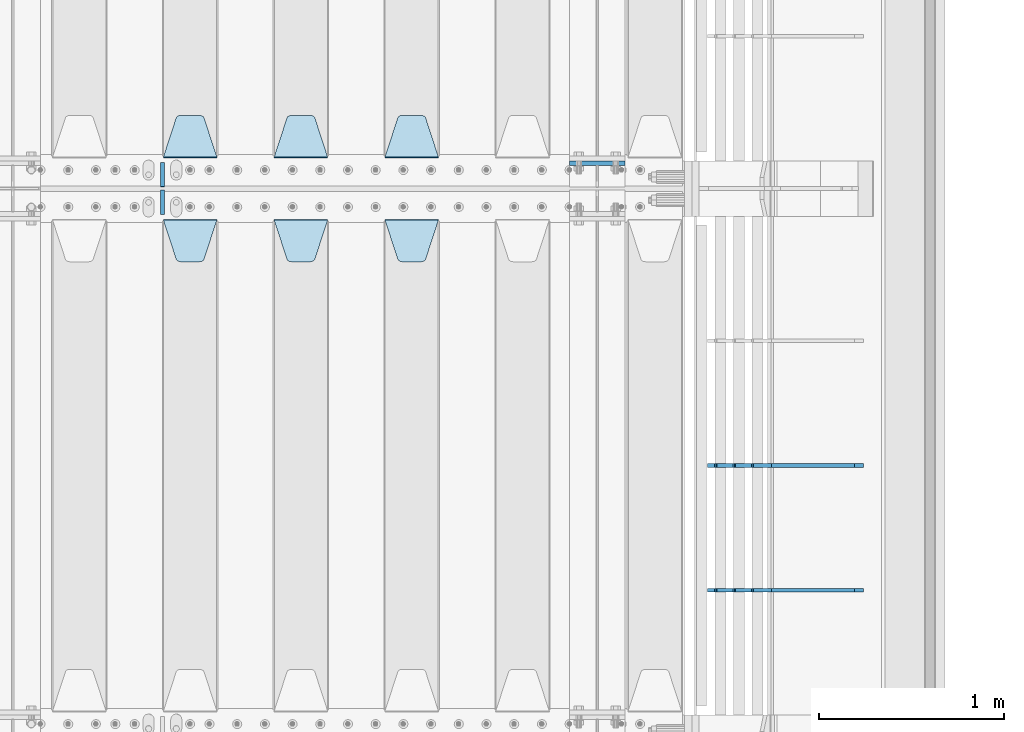
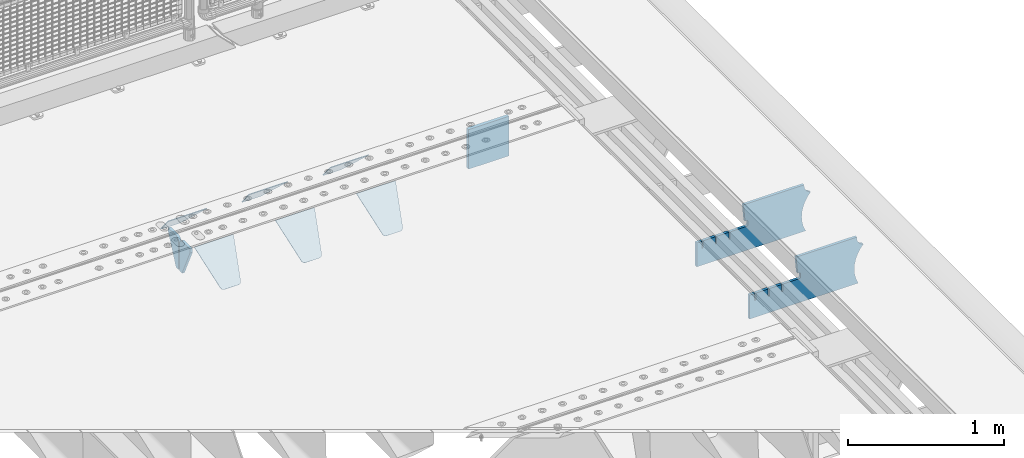
# One storey, part 190 of 219: 11 plates.
"""IFC2X3 building model written with IfcOpenShell, lengths in millimetres."""

from ifc_helpers import new_model, si_unit, frame, origin_with_axes, place, context, subcontext, project, spatial, faceted_brep, material, type_object, element, save


model = new_model("IFC2X3")

# Units and contexts
model_context = context("Model", 3, precision=1e-05, world=origin_with_axes())
body_context = subcontext(model_context, "Body", "Model", "MODEL_VIEW")
ifc_project = project(units=[si_unit("LENGTHUNIT", "METRE", prefix="MILLI"), si_unit("AREAUNIT", "SQUARE_METRE"), si_unit("VOLUMEUNIT", "CUBIC_METRE"), si_unit("MASSUNIT", "GRAM", prefix="KILO"), si_unit("TIMEUNIT", "SECOND"), si_unit("PLANEANGLEUNIT", "RADIAN"), si_unit("SOLIDANGLEUNIT", "STERADIAN"), si_unit("THERMODYNAMICTEMPERATUREUNIT", "DEGREE_CELSIUS"), si_unit("LUMINOUSINTENSITYUNIT", "LUMEN")], contexts=[model_context])

# Site, building, storey
site_placement = place(None, origin_with_axes())
site = spatial("IfcSite", under=ifc_project, at=site_placement, CompositionType="ELEMENT")
building_placement = place(site_placement, origin_with_axes())
building = spatial("IfcBuilding", under=site, at=building_placement, Name="Standard", CompositionType="ELEMENT")
storey_placement = place(building_placement, origin_with_axes())
storey = spatial("IfcBuildingStorey", under=building, at=storey_placement, Name="Undefined", CompositionType="ELEMENT", Elevation=0.0)

# Plates
ifc_material = material(Name="STEEL/S355N")
plate_type_1 = type_object("IfcPlateType", PredefinedType="NOTDEFINED")
plate_1_placement = place(storey_placement, frame((13405.0, 30137.5, -339.999999999995), z_axis=(0.0, 0.0, 1.0), x_axis=(1.0, 0.0, 0.0)))
element("IfcPlate", 1, at=plate_1_placement, inside=storey, type_object=plate_type_1, material=ifc_material, context=body_context, shape_type="Brep", body=[
    faceted_brep([(0.0, -12.5, 0.0), (0.0, -12.5, 310.0), (0.0, 12.5, 310.0), (0.0, 12.5, 0.0), (300.0, -12.5, 310.0), (300.0, 12.5, 310.0), (300.0, -12.5, 0.0), (300.0, 12.5, 0.0)], [[[0, 1, 2, 3]], [[1, 4, 5, 2]], [[4, 6, 7, 5]], [[6, 0, 3, 7]], [[5, 7, 3, 2]], [[6, 4, 1, 0]]]),
])
plate_type_2 = type_object("IfcPlateType", PredefinedType="NOTDEFINED")
plate_2_placement = place(storey_placement, frame((12405.0, 29831.767766956, -1.76776695296758), z_axis=(0.0, -0.707106781186547, -0.707106781186548), x_axis=(1.0, 0.0, 0.0)))
element("IfcPlate", 2, at=plate_2_placement, inside=storey, type_object=plate_type_2, material=ifc_material, context=body_context, shape_type="Brep", body=[
    faceted_brep([(0.0, -2.5, 0.0), (69.345504679477, -2.5, 300.171731424834), (69.345504679477, 2.49999999999636, 300.171731424831), (0.0, 2.5, 0.0), (70.9274061199576, -2.50000000000364, 304.8974424154), (70.9274061199576, 2.49999999999636, 304.8974424154), (73.3818627772307, -2.50000000000364, 309.234538108532), (73.3818627772307, 2.49999999999636, 309.234538108532), (76.6187032999569, -2.50000000000364, 313.023683126106), (76.6187032999569, 2.49999999999636, 313.023683126106), (80.5190132704993, -2.50000000000364, 316.125672595372), (80.5190132704993, 2.49999999999636, 316.125672595372), (84.9395038596831, -2.50000000000364, 318.426546230476), (84.9395038596831, 2.5, 318.426546230479), (89.7177759439237, -2.50000000000364, 319.841774983277), (89.7177759439237, 2.5, 319.841774983281), (94.6782862926502, -2.50000000000364, 320.319366455078), (94.6782862926502, 2.49999999999636, 320.319366455078), (195.32171370735, -2.50000000000364, 320.319366455078), (195.32171370735, 2.49999999999636, 320.319366455078), (200.282224056076, -2.50000000000364, 319.841774983277), (200.282224056076, 2.5, 319.841774983281), (205.060496140317, -2.50000000000364, 318.426546230476), (205.060496140317, 2.49999999999636, 318.426546230476), (209.480986729501, -2.50000000000364, 316.125672595372), (209.480986729501, 2.49999999999636, 316.125672595372), (213.381296700043, -2.50000000000364, 313.023683126106), (213.381296700043, 2.49999999999272, 313.023683126106), (216.618137222769, -2.50000000000364, 309.234538108529), (216.618137222769, 2.49999999999636, 309.234538108525), (219.072593880042, -2.50000000000364, 304.8974424154), (219.072593880042, 2.49999999999636, 304.8974424154), (220.654495320523, -2.5, 300.171731424834), (220.654495320523, 2.49999999999636, 300.171731424831), (290.0, -2.50000000000364, 3.63797880709171e-12), (290.0, 2.49999999999636, 0.0)], [[[0, 1, 2, 3]], [[1, 4, 5, 2]], [[4, 6, 7, 5]], [[6, 8, 9, 7]], [[8, 10, 11, 9]], [[10, 12, 13, 11]], [[12, 14, 15, 13]], [[14, 16, 17, 15]], [[16, 18, 19, 17]], [[18, 20, 21, 19]], [[20, 22, 23, 21]], [[22, 24, 25, 23]], [[24, 26, 27, 25]], [[26, 28, 29, 27]], [[28, 30, 31, 29]], [[30, 32, 33, 31]], [[32, 34, 35, 33]], [[34, 0, 3, 35]], [[5, 7, 9, 11, 13, 15, 17, 19, 21, 23, 25, 27, 29, 31, 33, 35, 3, 2]], [[34, 32, 30, 28, 26, 24, 22, 20, 18, 16, 14, 12, 10, 8, 6, 4, 1, 0]]]),
])
plate_3_placement = place(storey_placement, frame((11805.0, 29831.767766956, -1.76776695296758), z_axis=(0.0, -0.707106781186547, -0.707106781186548), x_axis=(1.0, 0.0, 0.0)))
element("IfcPlate", 3, at=plate_3_placement, inside=storey, type_object=plate_type_2, material=ifc_material, context=body_context, shape_type="Brep", body=[
    faceted_brep([(0.0, -2.5, 0.0), (69.345504679477, -2.5, 300.171731424834), (69.345504679477, 2.49999999999636, 300.171731424831), (0.0, 2.5, 0.0), (70.9274061199576, -2.50000000000364, 304.8974424154), (70.9274061199576, 2.49999999999636, 304.8974424154), (73.3818627772307, -2.50000000000364, 309.234538108532), (73.3818627772307, 2.49999999999636, 309.234538108532), (76.6187032999569, -2.50000000000364, 313.023683126106), (76.6187032999569, 2.49999999999636, 313.023683126106), (80.5190132704993, -2.50000000000364, 316.125672595372), (80.5190132704993, 2.49999999999636, 316.125672595372), (84.9395038596831, -2.50000000000364, 318.426546230476), (84.9395038596831, 2.5, 318.426546230479), (89.7177759439237, -2.50000000000364, 319.841774983277), (89.7177759439237, 2.5, 319.841774983281), (94.6782862926502, -2.50000000000364, 320.319366455078), (94.6782862926502, 2.49999999999636, 320.319366455078), (195.32171370735, -2.50000000000364, 320.319366455078), (195.32171370735, 2.49999999999636, 320.319366455078), (200.282224056076, -2.50000000000364, 319.841774983277), (200.282224056076, 2.5, 319.841774983281), (205.060496140317, -2.50000000000364, 318.426546230476), (205.060496140317, 2.49999999999636, 318.426546230476), (209.480986729501, -2.50000000000364, 316.125672595372), (209.480986729501, 2.49999999999636, 316.125672595372), (213.381296700043, -2.50000000000364, 313.023683126106), (213.381296700043, 2.49999999999272, 313.023683126106), (216.618137222769, -2.50000000000364, 309.234538108529), (216.618137222769, 2.49999999999636, 309.234538108525), (219.072593880042, -2.50000000000364, 304.8974424154), (219.072593880042, 2.49999999999636, 304.8974424154), (220.654495320523, -2.5, 300.171731424834), (220.654495320523, 2.49999999999636, 300.171731424831), (290.0, -2.50000000000364, 3.63797880709171e-12), (290.0, 2.49999999999636, 0.0)], [[[0, 1, 2, 3]], [[1, 4, 5, 2]], [[4, 6, 7, 5]], [[6, 8, 9, 7]], [[8, 10, 11, 9]], [[10, 12, 13, 11]], [[12, 14, 15, 13]], [[14, 16, 17, 15]], [[16, 18, 19, 17]], [[18, 20, 21, 19]], [[20, 22, 23, 21]], [[22, 24, 25, 23]], [[24, 26, 27, 25]], [[26, 28, 29, 27]], [[28, 30, 31, 29]], [[30, 32, 33, 31]], [[32, 34, 35, 33]], [[34, 0, 3, 35]], [[5, 7, 9, 11, 13, 15, 17, 19, 21, 23, 25, 27, 29, 31, 33, 35, 3, 2]], [[34, 32, 30, 28, 26, 24, 22, 20, 18, 16, 14, 12, 10, 8, 6, 4, 1, 0]]]),
])
plate_4_placement = place(storey_placement, frame((11205.0, 29831.767766956, -1.76776695296758), z_axis=(0.0, -0.707106781186547, -0.707106781186548), x_axis=(1.0, 0.0, 0.0)))
element("IfcPlate", 4, at=plate_4_placement, inside=storey, type_object=plate_type_2, material=ifc_material, context=body_context, shape_type="Brep", body=[
    faceted_brep([(0.0, -2.5, 0.0), (69.345504679477, -2.5, 300.171731424834), (69.345504679477, 2.49999999999636, 300.171731424831), (0.0, 2.5, 0.0), (70.9274061199576, -2.50000000000364, 304.8974424154), (70.9274061199576, 2.49999999999636, 304.8974424154), (73.3818627772307, -2.50000000000364, 309.234538108532), (73.3818627772307, 2.49999999999636, 309.234538108532), (76.6187032999569, -2.50000000000364, 313.023683126106), (76.6187032999569, 2.49999999999636, 313.023683126106), (80.5190132704993, -2.50000000000364, 316.125672595372), (80.5190132704993, 2.49999999999636, 316.125672595372), (84.9395038596831, -2.50000000000364, 318.426546230476), (84.9395038596831, 2.5, 318.426546230479), (89.7177759439237, -2.50000000000364, 319.841774983277), (89.7177759439237, 2.5, 319.841774983281), (94.6782862926502, -2.50000000000364, 320.319366455078), (94.6782862926502, 2.49999999999636, 320.319366455078), (195.32171370735, -2.50000000000364, 320.319366455078), (195.32171370735, 2.49999999999636, 320.319366455078), (200.282224056076, -2.50000000000364, 319.841774983277), (200.282224056076, 2.5, 319.841774983281), (205.060496140317, -2.50000000000364, 318.426546230476), (205.060496140317, 2.49999999999636, 318.426546230476), (209.480986729501, -2.50000000000364, 316.125672595372), (209.480986729501, 2.49999999999636, 316.125672595372), (213.381296700043, -2.50000000000364, 313.023683126106), (213.381296700043, 2.49999999999272, 313.023683126106), (216.618137222769, -2.50000000000364, 309.234538108529), (216.618137222769, 2.49999999999636, 309.234538108525), (219.072593880042, -2.50000000000364, 304.8974424154), (219.072593880042, 2.49999999999636, 304.8974424154), (220.654495320523, -2.5, 300.171731424834), (220.654495320523, 2.49999999999636, 300.171731424831), (290.0, -2.50000000000364, 3.63797880709171e-12), (290.0, 2.49999999999636, 0.0)], [[[0, 1, 2, 3]], [[1, 4, 5, 2]], [[4, 6, 7, 5]], [[6, 8, 9, 7]], [[8, 10, 11, 9]], [[10, 12, 13, 11]], [[12, 14, 15, 13]], [[14, 16, 17, 15]], [[16, 18, 19, 17]], [[18, 20, 21, 19]], [[20, 22, 23, 21]], [[22, 24, 25, 23]], [[24, 26, 27, 25]], [[26, 28, 29, 27]], [[28, 30, 31, 29]], [[30, 32, 33, 31]], [[32, 34, 35, 33]], [[34, 0, 3, 35]], [[5, 7, 9, 11, 13, 15, 17, 19, 21, 23, 25, 27, 29, 31, 33, 35, 3, 2]], [[34, 32, 30, 28, 26, 24, 22, 20, 18, 16, 14, 12, 10, 8, 6, 4, 1, 0]]]),
])
plate_5_placement = place(storey_placement, frame((12695.0, 30168.232233047, -1.76776695296758), z_axis=(0.0, 0.707106781186547, -0.707106781186548), x_axis=(-1.0, 0.0, 0.0)))
element("IfcPlate", 5, at=plate_5_placement, inside=storey, type_object=plate_type_2, material=ifc_material, context=body_context, shape_type="Brep", body=[
    faceted_brep([(0.0, -2.5, 0.0), (69.345504679477, -2.5, 300.171731424834), (69.345504679477, 2.49999999999636, 300.171731424831), (0.0, 2.5, 0.0), (70.9274061199576, -2.50000000000364, 304.8974424154), (70.9274061199576, 2.49999999999636, 304.8974424154), (73.3818627772307, -2.50000000000364, 309.234538108532), (73.3818627772307, 2.49999999999636, 309.234538108532), (76.6187032999569, -2.50000000000364, 313.023683126106), (76.6187032999569, 2.49999999999636, 313.023683126106), (80.5190132704993, -2.50000000000364, 316.125672595372), (80.5190132704993, 2.49999999999636, 316.125672595372), (84.9395038596831, -2.50000000000364, 318.426546230476), (84.9395038596831, 2.5, 318.426546230479), (89.7177759439237, -2.50000000000364, 319.841774983277), (89.7177759439237, 2.5, 319.841774983281), (94.6782862926502, -2.50000000000364, 320.319366455078), (94.6782862926502, 2.49999999999636, 320.319366455078), (195.32171370735, -2.50000000000364, 320.319366455078), (195.32171370735, 2.49999999999636, 320.319366455078), (200.282224056076, -2.50000000000364, 319.841774983277), (200.282224056076, 2.5, 319.841774983281), (205.060496140317, -2.50000000000364, 318.426546230476), (205.060496140317, 2.49999999999636, 318.426546230476), (209.480986729501, -2.50000000000364, 316.125672595372), (209.480986729501, 2.49999999999636, 316.125672595372), (213.381296700043, -2.50000000000364, 313.023683126106), (213.381296700043, 2.49999999999272, 313.023683126106), (216.618137222769, -2.50000000000364, 309.234538108529), (216.618137222769, 2.49999999999636, 309.234538108525), (219.072593880042, -2.50000000000364, 304.8974424154), (219.072593880042, 2.49999999999636, 304.8974424154), (220.654495320523, -2.5, 300.171731424834), (220.654495320523, 2.49999999999636, 300.171731424831), (290.0, -2.50000000000364, 3.63797880709171e-12), (290.0, 2.49999999999636, 0.0)], [[[0, 1, 2, 3]], [[1, 4, 5, 2]], [[4, 6, 7, 5]], [[6, 8, 9, 7]], [[8, 10, 11, 9]], [[10, 12, 13, 11]], [[12, 14, 15, 13]], [[14, 16, 17, 15]], [[16, 18, 19, 17]], [[18, 20, 21, 19]], [[20, 22, 23, 21]], [[22, 24, 25, 23]], [[24, 26, 27, 25]], [[26, 28, 29, 27]], [[28, 30, 31, 29]], [[30, 32, 33, 31]], [[32, 34, 35, 33]], [[34, 0, 3, 35]], [[5, 7, 9, 11, 13, 15, 17, 19, 21, 23, 25, 27, 29, 31, 33, 35, 3, 2]], [[34, 32, 30, 28, 26, 24, 22, 20, 18, 16, 14, 12, 10, 8, 6, 4, 1, 0]]]),
])
plate_6_placement = place(storey_placement, frame((12095.0, 30168.232233047, -1.76776695296758), z_axis=(0.0, 0.707106781186547, -0.707106781186548), x_axis=(-1.0, 0.0, 0.0)))
element("IfcPlate", 6, at=plate_6_placement, inside=storey, type_object=plate_type_2, material=ifc_material, context=body_context, shape_type="Brep", body=[
    faceted_brep([(0.0, -2.5, 0.0), (69.345504679477, -2.5, 300.171731424834), (69.345504679477, 2.49999999999636, 300.171731424831), (0.0, 2.5, 0.0), (70.9274061199576, -2.50000000000364, 304.8974424154), (70.9274061199576, 2.49999999999636, 304.8974424154), (73.3818627772307, -2.50000000000364, 309.234538108532), (73.3818627772307, 2.49999999999636, 309.234538108532), (76.6187032999569, -2.50000000000364, 313.023683126106), (76.6187032999569, 2.49999999999636, 313.023683126106), (80.5190132704993, -2.50000000000364, 316.125672595372), (80.5190132704993, 2.49999999999636, 316.125672595372), (84.9395038596831, -2.50000000000364, 318.426546230476), (84.9395038596831, 2.5, 318.426546230479), (89.7177759439237, -2.50000000000364, 319.841774983277), (89.7177759439237, 2.5, 319.841774983281), (94.6782862926502, -2.50000000000364, 320.319366455078), (94.6782862926502, 2.49999999999636, 320.319366455078), (195.32171370735, -2.50000000000364, 320.319366455078), (195.32171370735, 2.49999999999636, 320.319366455078), (200.282224056076, -2.50000000000364, 319.841774983277), (200.282224056076, 2.5, 319.841774983281), (205.060496140317, -2.50000000000364, 318.426546230476), (205.060496140317, 2.49999999999636, 318.426546230476), (209.480986729501, -2.50000000000364, 316.125672595372), (209.480986729501, 2.49999999999636, 316.125672595372), (213.381296700043, -2.50000000000364, 313.023683126106), (213.381296700043, 2.49999999999272, 313.023683126106), (216.618137222769, -2.50000000000364, 309.234538108529), (216.618137222769, 2.49999999999636, 309.234538108525), (219.072593880042, -2.50000000000364, 304.8974424154), (219.072593880042, 2.49999999999636, 304.8974424154), (220.654495320523, -2.5, 300.171731424834), (220.654495320523, 2.49999999999636, 300.171731424831), (290.0, -2.50000000000364, 3.63797880709171e-12), (290.0, 2.49999999999636, 0.0)], [[[0, 1, 2, 3]], [[1, 4, 5, 2]], [[4, 6, 7, 5]], [[6, 8, 9, 7]], [[8, 10, 11, 9]], [[10, 12, 13, 11]], [[12, 14, 15, 13]], [[14, 16, 17, 15]], [[16, 18, 19, 17]], [[18, 20, 21, 19]], [[20, 22, 23, 21]], [[22, 24, 25, 23]], [[24, 26, 27, 25]], [[26, 28, 29, 27]], [[28, 30, 31, 29]], [[30, 32, 33, 31]], [[32, 34, 35, 33]], [[34, 0, 3, 35]], [[5, 7, 9, 11, 13, 15, 17, 19, 21, 23, 25, 27, 29, 31, 33, 35, 3, 2]], [[34, 32, 30, 28, 26, 24, 22, 20, 18, 16, 14, 12, 10, 8, 6, 4, 1, 0]]]),
])
plate_7_placement = place(storey_placement, frame((11495.0, 30168.232233047, -1.76776695296758), z_axis=(0.0, 0.707106781186547, -0.707106781186548), x_axis=(-1.0, 0.0, 0.0)))
element("IfcPlate", 7, at=plate_7_placement, inside=storey, type_object=plate_type_2, material=ifc_material, context=body_context, shape_type="Brep", body=[
    faceted_brep([(0.0, -2.5, 0.0), (69.345504679477, -2.5, 300.171731424834), (69.345504679477, 2.49999999999636, 300.171731424831), (0.0, 2.5, 0.0), (70.9274061199576, -2.50000000000364, 304.8974424154), (70.9274061199576, 2.49999999999636, 304.8974424154), (73.3818627772307, -2.50000000000364, 309.234538108532), (73.3818627772307, 2.49999999999636, 309.234538108532), (76.6187032999569, -2.50000000000364, 313.023683126106), (76.6187032999569, 2.49999999999636, 313.023683126106), (80.5190132704993, -2.50000000000364, 316.125672595372), (80.5190132704993, 2.49999999999636, 316.125672595372), (84.9395038596831, -2.50000000000364, 318.426546230476), (84.9395038596831, 2.5, 318.426546230479), (89.7177759439237, -2.50000000000364, 319.841774983277), (89.7177759439237, 2.5, 319.841774983281), (94.6782862926502, -2.50000000000364, 320.319366455078), (94.6782862926502, 2.49999999999636, 320.319366455078), (195.32171370735, -2.50000000000364, 320.319366455078), (195.32171370735, 2.49999999999636, 320.319366455078), (200.282224056076, -2.50000000000364, 319.841774983277), (200.282224056076, 2.5, 319.841774983281), (205.060496140317, -2.50000000000364, 318.426546230476), (205.060496140317, 2.49999999999636, 318.426546230476), (209.480986729501, -2.50000000000364, 316.125672595372), (209.480986729501, 2.49999999999636, 316.125672595372), (213.381296700043, -2.50000000000364, 313.023683126106), (213.381296700043, 2.49999999999272, 313.023683126106), (216.618137222769, -2.50000000000364, 309.234538108529), (216.618137222769, 2.49999999999636, 309.234538108525), (219.072593880042, -2.50000000000364, 304.8974424154), (219.072593880042, 2.49999999999636, 304.8974424154), (220.654495320523, -2.5, 300.171731424834), (220.654495320523, 2.49999999999636, 300.171731424831), (290.0, -2.50000000000364, 3.63797880709171e-12), (290.0, 2.49999999999636, 0.0)], [[[0, 1, 2, 3]], [[1, 4, 5, 2]], [[4, 6, 7, 5]], [[6, 8, 9, 7]], [[8, 10, 11, 9]], [[10, 12, 13, 11]], [[12, 14, 15, 13]], [[14, 16, 17, 15]], [[16, 18, 19, 17]], [[18, 20, 21, 19]], [[20, 22, 23, 21]], [[22, 24, 25, 23]], [[24, 26, 27, 25]], [[26, 28, 29, 27]], [[28, 30, 31, 29]], [[30, 32, 33, 31]], [[32, 34, 35, 33]], [[34, 0, 3, 35]], [[5, 7, 9, 11, 13, 15, 17, 19, 21, 23, 25, 27, 29, 31, 33, 35, 3, 2]], [[34, 32, 30, 28, 26, 24, 22, 20, 18, 16, 14, 12, 10, 8, 6, 4, 1, 0]]]),
])
plate_type_3 = type_object("IfcPlateType", PredefinedType="NOTDEFINED")
for number, where, z_axis, x_axis in (
    (8, (11200.0, 30140.0, -30.0), (0.0, 0.0, -1.0), (0.0, -1.0, 0.0)),
    (9, (11200.0, 29860.0, -30.0), (0.0, 0.0, -1.0), (0.0, 1.0, 0.0)),
):
    element("IfcPlate", number, at=place(storey_placement, frame(where, z_axis=z_axis, x_axis=x_axis)), inside=storey, type_object=plate_type_3, material=ifc_material, context=body_context, shape_type="Brep", body=[
        faceted_brep([(0.0, -10.0, 0.0), (0.0, -10.0, 30.0), (0.0, 10.0, 30.0), (0.0, 10.0, 0.0), (102.0, -10.0, 250.0), (102.0, 10.0, 250.0), (132.0, -10.0, 250.0), (132.0, 10.0, 250.0), (132.0, -10.0, 30.0), (132.0, 10.0, 30.0), (131.544232590368, -10.0, 24.790554669992), (131.544232590368, 10.0, 24.790554669992), (130.190778623579, -10.0, 19.7393957002299), (130.190778623579, 10.0, 19.7393957002299), (127.980762113533, -10.0, 15.0), (127.980762113533, 10.0, 15.0), (124.98133329357, -10.0, 10.7163717094038), (124.98133329357, 10.0, 10.7163717094038), (121.283628290596, -10.0, 7.01866670643062), (121.283628290596, 10.0, 7.01866670643062), (117.0, -10.0, 4.01923788646684), (117.0, 10.0, 4.01923788646684), (112.260604299769, -10.0, 1.80922137642278), (112.260604299769, 10.0, 1.80922137642278), (107.209445330009, -10.0, 0.455767409633722), (107.209445330009, 10.0, 0.455767409633722), (102.0, -10.0, 0.0), (102.0, 10.0, 0.0)], [[[0, 1, 2, 3]], [[1, 4, 5, 2]], [[4, 6, 7, 5]], [[6, 8, 9, 7]], [[8, 10, 11, 9]], [[10, 12, 13, 11]], [[12, 14, 15, 13]], [[14, 16, 17, 15]], [[16, 18, 19, 17]], [[18, 20, 21, 19]], [[20, 22, 23, 21]], [[22, 24, 25, 23]], [[24, 26, 27, 25]], [[26, 0, 3, 27]], [[5, 7, 9, 11, 13, 15, 17, 19, 21, 23, 25, 27, 3, 2]], [[26, 24, 22, 20, 18, 16, 14, 12, 10, 8, 6, 4, 1, 0]]]),
    ])
plate_type_4 = type_object("IfcPlateType", PredefinedType="NOTDEFINED")
plate_8_placement = place(storey_placement, frame((14992.9182339676, 27824.9992828369, -374.002067436517), z_axis=(0.0, 0.0, 1.0), x_axis=(-1.0, 0.0, 0.0)))
element("IfcPlate", 10, at=plate_8_placement, inside=storey, type_object=plate_type_4, material=ifc_material, context=body_context, shape_type="Brep", body=[
    faceted_brep([(801.919404066546, -10.0, 188.0), (801.919404066546, 10.0, 188.0), (801.919404066546, 10.0, 132.002067436952), (801.919404066546, -9.99999999999636, 132.002067436952), (793.919404066546, 10.0, 132.002067436952), (793.919404066546, -9.99999999999636, 132.002067436952), (793.919404066546, 10.0, 180.002067436952), (793.919404066546, -10.0, 180.002067436952), (793.527856196908, 10.0, 182.474203391951), (793.527856196908, -10.0, 182.474203391951), (792.391540021546, 10.0, 184.704349455291), (792.391540021546, -10.0, 184.704349455291), (790.621686084885, 10.0, 186.474203391951), (790.621686084885, -10.0, 186.474203391951), (788.391540021546, 10.0, 187.610519567313), (788.391540021546, -10.0, 187.610519567313), (785.919404066546, -10.0, 188.002067436952), (785.919404066546, 10.0, 188.0), (841.0, -10.0, 188.0), (841.0, -10.0, 0.0), (841.0, 10.0, 0.0), (841.0, 10.0, 188.0), (33.3619566736033, -10.0, 0.0), (33.3619566736033, 10.0, 0.0), (36.2350612208174, -10.0, 4.68848050267013), (36.2350612208174, 10.0, 4.68848050267013), (51.487759215941, -10.0, 41.5117508652784), (51.487759215941, 10.0, 41.5117508652784), (60.792242588137, -10.0, 80.2677133162964), (60.792242588137, 10.0, 80.2677133162964), (63.9194040769726, -10.0, 120.002067436515), (63.9194040769726, 10.0, 120.002067436515), (60.792242588137, -10.0, 159.736421556734), (60.792242588137, 10.0, 159.736421556734), (51.487759215941, -10.0, 198.492384007752), (51.487759215941, 10.0, 198.492384007752), (36.2350612208174, -10.0, 235.31565437036), (36.2350612208174, 10.0, 235.31565437036), (15.4097206482093, -10.0, 269.299521518803), (15.4097206482093, 10.0, 269.299521518803), (-3.35474438098936, -10.0, 291.269887256574), (-3.35474438098936, 10.0, 291.269887256574), (-2.36881039375294, -10.0, 291.426043859339), (-2.36881039375294, 10.0, 291.426043859339), (17.1449676604734, -10.0, 301.368810393754), (17.1449676604734, 10.0, 301.368810393754), (32.6311896062471, -10.0, 316.855032339527), (32.6311896062471, 10.0, 316.855032339527), (42.5739561406608, -10.0, 336.368810393754), (42.5739561406608, 10.0, 336.368810393754), (46.0, -10.0, 358.0), (46.0, 10.0, 358.0), (45.0495205499192, -10.0, 364.001091067617), (45.0495205499192, 10.0, 364.001091067617), (495.040008544922, -10.0, 364.010009765625), (495.040008544922, 10.0, 364.010009765625), (483.600036621094, -10.0, 233.759994506836), (483.600036621094, 10.0, 233.759994506836), (472.0, -10.0, 233.759994506836), (472.0, 10.0, 233.759994506836), (468.909830056251, -10.0, 233.270559669787), (468.909830056251, 10.0, 233.270559669787), (466.122147477075, -10.0, 231.850164450585), (466.122147477075, 10.0, 231.850164450585), (463.909830056251, -10.0, 229.637847029761), (463.909830056251, 10.0, 229.637847029761), (462.489434837049, -10.0, 226.850164450585), (462.489434837049, 10.0, 226.850164450585), (462.0, -10.0, 223.759994506836), (462.0, 10.0, 223.759994506836), (462.0, -10.0, 198.0), (462.0, 10.0, 198.0), (462.489434837049, -10.0, 194.909830056251), (462.489434837049, 10.0, 194.909830056251), (463.909830056251, -10.0, 192.122147477075), (463.909830056251, 10.0, 192.122147477075), (466.122147477075, -10.0, 189.909830056251), (466.122147477075, 10.0, 189.909830056251), (468.909830056251, -10.0, 188.489434837048), (468.909830056251, 10.0, 188.489434837048), (472.0, -10.0, 188.0), (472.0, 10.0, 188.0), (585.919404066546, -10.0, 188.002067436952), (585.919404066546, 10.0, 188.0), (588.391540021546, -10.0, 187.610519567313), (588.391540021546, 10.0, 187.610519567313), (590.621686084885, -10.0, 186.474203391951), (590.621686084885, 10.0, 186.474203391951), (592.391540021546, -10.0, 184.704349455291), (592.391540021546, 10.0, 184.704349455291), (593.527856196908, -10.0, 182.474203391951), (593.527856196908, 10.0, 182.474203391951), (593.919404066546, -10.0, 180.002067436952), (593.919404066546, 10.0, 180.002067436952), (593.919404066546, -10.0, 132.002067436952), (593.919404066546, 10.0, 132.002067436952), (601.919404066546, -10.0, 132.002067436952), (601.919404066546, 10.0, 132.002067436952), (601.919404066546, -10.0, 188.0), (601.919404066546, 10.0, 188.0), (685.919404066546, -10.0, 188.002067436952), (685.919404066546, 10.0, 188.0), (688.391540021546, -10.0, 187.610519567313), (688.391540021546, 10.0, 187.610519567313), (690.621686084885, -10.0, 186.474203391951), (690.621686084885, 10.0, 186.474203391951), (692.391540021546, -10.0, 184.704349455291), (692.391540021546, 10.0, 184.704349455291), (693.527856196908, -10.0, 182.474203391951), (693.527856196908, 10.0, 182.474203391951), (693.919404066546, -10.0, 180.002067436952), (693.919404066546, 10.0, 180.002067436952), (693.919404066546, -10.0, 132.002067436952), (693.919404066546, 10.0, 132.002067436952), (701.919404066546, -10.0, 132.002067436952), (701.919404066546, 10.0, 132.002067436952), (701.919404066546, -10.0, 188.0), (701.919404066546, 10.0, 188.0)], [[[0, 1, 2, 3]], [[3, 2, 4, 5]], [[5, 4, 6, 7]], [[7, 6, 8, 9]], [[9, 8, 10, 11]], [[11, 10, 12, 13]], [[13, 12, 14, 15]], [[16, 15, 14, 17]], [[18, 19, 20, 21]], [[20, 19, 22, 23]], [[22, 24, 25, 23]], [[26, 27, 25, 24]], [[28, 29, 27, 26]], [[30, 31, 29, 28]], [[32, 33, 31, 30]], [[34, 35, 33, 32]], [[36, 37, 35, 34]], [[38, 39, 37, 36]], [[39, 38, 40, 41]], [[40, 42, 43, 41]], [[44, 45, 43, 42]], [[46, 47, 45, 44]], [[48, 49, 47, 46]], [[50, 51, 49, 48]], [[52, 53, 51, 50]], [[54, 55, 53, 52]], [[54, 56, 57, 55]], [[56, 58, 59, 57]], [[58, 60, 61, 59]], [[60, 62, 63, 61]], [[62, 64, 65, 63]], [[64, 66, 67, 65]], [[66, 68, 69, 67]], [[68, 70, 71, 69]], [[70, 72, 73, 71]], [[72, 74, 75, 73]], [[74, 76, 77, 75]], [[76, 78, 79, 77]], [[78, 80, 81, 79]], [[81, 80, 82, 83]], [[82, 84, 85, 83]], [[86, 87, 85, 84]], [[88, 89, 87, 86]], [[90, 91, 89, 88]], [[92, 93, 91, 90]], [[94, 95, 93, 92]], [[96, 97, 95, 94]], [[98, 99, 97, 96]], [[99, 98, 100, 101]], [[100, 102, 103, 101]], [[104, 105, 103, 102]], [[106, 107, 105, 104]], [[108, 109, 107, 106]], [[110, 111, 109, 108]], [[112, 113, 111, 110]], [[114, 115, 113, 112]], [[116, 117, 115, 114]], [[117, 116, 16, 17]], [[12, 10, 8, 6, 4, 2, 1, 21, 20, 23, 25, 27, 29, 31, 33, 35, 37, 39, 41, 43, 45, 47, 49, 51, 53, 55, 57, 59, 61, 63, 65, 67, 69, 71, 73, 75, 77, 79, 81, 83, 85, 87, 89, 91, 93, 95, 97, 99, 101, 103, 105, 107, 109, 111, 113, 115, 117, 17, 14]], [[18, 21, 1, 0]], [[116, 114, 112, 110, 108, 106, 104, 102, 100, 98, 96, 94, 92, 90, 88, 86, 84, 82, 80, 78, 76, 74, 72, 70, 68, 66, 64, 62, 60, 58, 56, 54, 52, 50, 48, 46, 44, 42, 40, 38, 36, 34, 32, 30, 28, 26, 24, 22, 19, 18, 0, 3, 5, 7, 9, 11, 13, 15, 16]]]),
])
plate_9_placement = place(storey_placement, frame((14992.9182339676, 28499.9992828369, -374.002067436517), z_axis=(0.0, 0.0, 1.0), x_axis=(-1.0, 0.0, 0.0)))
element("IfcPlate", 11, at=plate_9_placement, inside=storey, type_object=plate_type_4, material=ifc_material, context=body_context, shape_type="Brep", body=[
    faceted_brep([(801.919404066546, -10.0, 188.0), (801.919404066546, 10.0, 188.0), (801.919404066546, 10.0, 132.002067436952), (801.919404066546, -9.99999999999636, 132.002067436952), (793.919404066546, 10.0, 132.002067436952), (793.919404066546, -9.99999999999636, 132.002067436952), (793.919404066546, 10.0, 180.002067436952), (793.919404066546, -10.0, 180.002067436952), (793.527856196908, 10.0, 182.474203391951), (793.527856196908, -10.0, 182.474203391951), (792.391540021546, 10.0, 184.704349455291), (792.391540021546, -10.0, 184.704349455291), (790.621686084885, 10.0, 186.474203391951), (790.621686084885, -10.0, 186.474203391951), (788.391540021546, 10.0, 187.610519567313), (788.391540021546, -10.0, 187.610519567313), (785.919404066546, -10.0, 188.002067436952), (785.919404066546, 10.0, 188.0), (841.0, -10.0, 188.0), (841.0, -10.0, 0.0), (841.0, 10.0, 0.0), (841.0, 10.0, 188.0), (33.3619566736033, -10.0, 0.0), (33.3619566736033, 10.0, 0.0), (36.2350612208174, -10.0, 4.68848050267013), (36.2350612208174, 10.0, 4.68848050267013), (51.487759215941, -10.0, 41.5117508652784), (51.487759215941, 10.0, 41.5117508652784), (60.792242588137, -10.0, 80.2677133162964), (60.792242588137, 10.0, 80.2677133162964), (63.9194040769726, -10.0, 120.002067436515), (63.9194040769726, 10.0, 120.002067436515), (60.792242588137, -10.0, 159.736421556734), (60.792242588137, 10.0, 159.736421556734), (51.487759215941, -10.0, 198.492384007752), (51.487759215941, 10.0, 198.492384007752), (36.2350612208174, -10.0, 235.31565437036), (36.2350612208174, 10.0, 235.31565437036), (15.4097206482093, -10.0, 269.299521518803), (15.4097206482093, 10.0, 269.299521518803), (-3.35474438098936, -10.0, 291.269887256574), (-3.35474438098936, 10.0, 291.269887256574), (-2.36881039375294, -10.0, 291.426043859339), (-2.36881039375294, 10.0, 291.426043859339), (17.1449676604734, -10.0, 301.368810393754), (17.1449676604734, 10.0, 301.368810393754), (32.6311896062471, -10.0, 316.855032339527), (32.6311896062471, 10.0, 316.855032339527), (42.5739561406608, -10.0, 336.368810393754), (42.5739561406608, 10.0, 336.368810393754), (46.0, -10.0, 358.0), (46.0, 10.0, 358.0), (45.0495205499192, -10.0, 364.001091067617), (45.0495205499192, 10.0, 364.001091067617), (495.040008544922, -10.0, 364.010009765625), (495.040008544922, 10.0, 364.010009765625), (483.600036621094, -10.0, 233.759994506836), (483.600036621094, 10.0, 233.759994506836), (472.0, -10.0, 233.759994506836), (472.0, 10.0, 233.759994506836), (468.909830056251, -10.0, 233.270559669787), (468.909830056251, 10.0, 233.270559669787), (466.122147477075, -10.0, 231.850164450585), (466.122147477075, 10.0, 231.850164450585), (463.909830056251, -10.0, 229.637847029761), (463.909830056251, 10.0, 229.637847029761), (462.489434837049, -10.0, 226.850164450585), (462.489434837049, 10.0, 226.850164450585), (462.0, -10.0, 223.759994506836), (462.0, 10.0, 223.759994506836), (462.0, -10.0, 198.0), (462.0, 10.0, 198.0), (462.489434837049, -10.0, 194.909830056251), (462.489434837049, 10.0, 194.909830056251), (463.909830056251, -10.0, 192.122147477075), (463.909830056251, 10.0, 192.122147477075), (466.122147477075, -10.0, 189.909830056251), (466.122147477075, 10.0, 189.909830056251), (468.909830056251, -10.0, 188.489434837048), (468.909830056251, 10.0, 188.489434837048), (472.0, -10.0, 188.0), (472.0, 10.0, 188.0), (585.919404066546, -10.0, 188.002067436952), (585.919404066546, 10.0, 188.0), (588.391540021546, -10.0, 187.610519567313), (588.391540021546, 10.0, 187.610519567313), (590.621686084885, -10.0, 186.474203391951), (590.621686084885, 10.0, 186.474203391951), (592.391540021546, -10.0, 184.704349455291), (592.391540021546, 10.0, 184.704349455291), (593.527856196908, -10.0, 182.474203391951), (593.527856196908, 10.0, 182.474203391951), (593.919404066546, -10.0, 180.002067436952), (593.919404066546, 10.0, 180.002067436952), (593.919404066546, -10.0, 132.002067436952), (593.919404066546, 10.0, 132.002067436952), (601.919404066546, -10.0, 132.002067436952), (601.919404066546, 10.0, 132.002067436952), (601.919404066546, -10.0, 188.0), (601.919404066546, 10.0, 188.0), (685.919404066546, -10.0, 188.002067436952), (685.919404066546, 10.0, 188.0), (688.391540021546, -10.0, 187.610519567313), (688.391540021546, 10.0, 187.610519567313), (690.621686084885, -10.0, 186.474203391951), (690.621686084885, 10.0, 186.474203391951), (692.391540021546, -10.0, 184.704349455291), (692.391540021546, 10.0, 184.704349455291), (693.527856196908, -10.0, 182.474203391951), (693.527856196908, 10.0, 182.474203391951), (693.919404066546, -10.0, 180.002067436952), (693.919404066546, 10.0, 180.002067436952), (693.919404066546, -10.0, 132.002067436952), (693.919404066546, 10.0, 132.002067436952), (701.919404066546, -10.0, 132.002067436952), (701.919404066546, 10.0, 132.002067436952), (701.919404066546, -10.0, 188.0), (701.919404066546, 10.0, 188.0)], [[[0, 1, 2, 3]], [[3, 2, 4, 5]], [[5, 4, 6, 7]], [[7, 6, 8, 9]], [[9, 8, 10, 11]], [[11, 10, 12, 13]], [[13, 12, 14, 15]], [[16, 15, 14, 17]], [[18, 19, 20, 21]], [[20, 19, 22, 23]], [[22, 24, 25, 23]], [[26, 27, 25, 24]], [[28, 29, 27, 26]], [[30, 31, 29, 28]], [[32, 33, 31, 30]], [[34, 35, 33, 32]], [[36, 37, 35, 34]], [[38, 39, 37, 36]], [[39, 38, 40, 41]], [[40, 42, 43, 41]], [[44, 45, 43, 42]], [[46, 47, 45, 44]], [[48, 49, 47, 46]], [[50, 51, 49, 48]], [[52, 53, 51, 50]], [[54, 55, 53, 52]], [[54, 56, 57, 55]], [[56, 58, 59, 57]], [[58, 60, 61, 59]], [[60, 62, 63, 61]], [[62, 64, 65, 63]], [[64, 66, 67, 65]], [[66, 68, 69, 67]], [[68, 70, 71, 69]], [[70, 72, 73, 71]], [[72, 74, 75, 73]], [[74, 76, 77, 75]], [[76, 78, 79, 77]], [[78, 80, 81, 79]], [[81, 80, 82, 83]], [[82, 84, 85, 83]], [[86, 87, 85, 84]], [[88, 89, 87, 86]], [[90, 91, 89, 88]], [[92, 93, 91, 90]], [[94, 95, 93, 92]], [[96, 97, 95, 94]], [[98, 99, 97, 96]], [[99, 98, 100, 101]], [[100, 102, 103, 101]], [[104, 105, 103, 102]], [[106, 107, 105, 104]], [[108, 109, 107, 106]], [[110, 111, 109, 108]], [[112, 113, 111, 110]], [[114, 115, 113, 112]], [[116, 117, 115, 114]], [[117, 116, 16, 17]], [[12, 10, 8, 6, 4, 2, 1, 21, 20, 23, 25, 27, 29, 31, 33, 35, 37, 39, 41, 43, 45, 47, 49, 51, 53, 55, 57, 59, 61, 63, 65, 67, 69, 71, 73, 75, 77, 79, 81, 83, 85, 87, 89, 91, 93, 95, 97, 99, 101, 103, 105, 107, 109, 111, 113, 115, 117, 17, 14]], [[18, 21, 1, 0]], [[116, 114, 112, 110, 108, 106, 104, 102, 100, 98, 96, 94, 92, 90, 88, 86, 84, 82, 80, 78, 76, 74, 72, 70, 68, 66, 64, 62, 60, 58, 56, 54, 52, 50, 48, 46, 44, 42, 40, 38, 36, 34, 32, 30, 28, 26, 24, 22, 19, 18, 0, 3, 5, 7, 9, 11, 13, 15, 16]]]),
])

save(model, "model.ifc")
